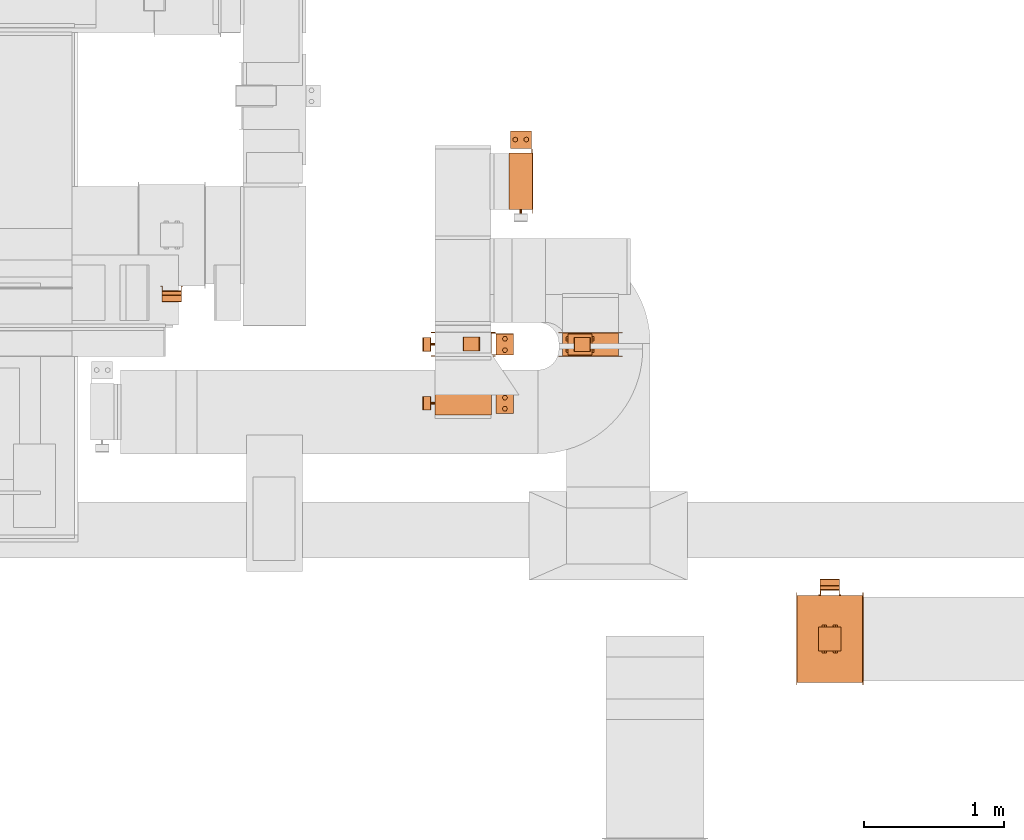
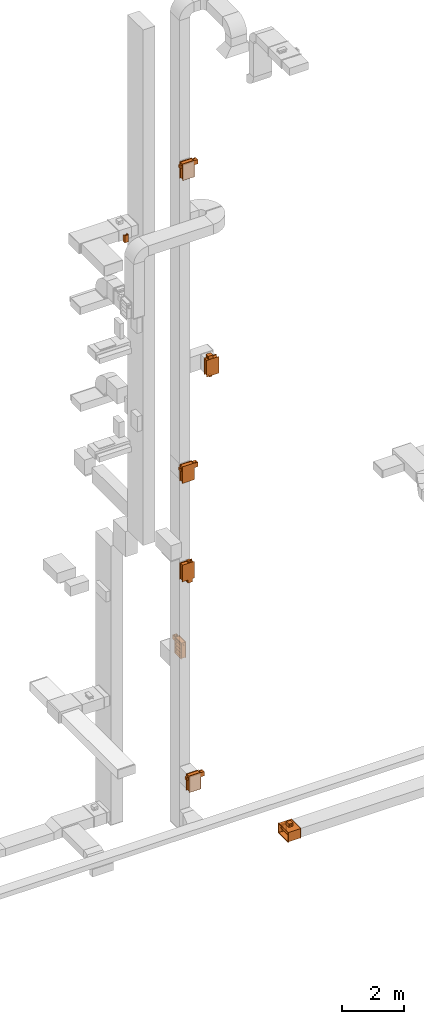
# One storey, part 22 of 25: 14 proxies.
"""IFC2X3 building model written with IfcOpenShell, lengths in millimetres."""

from ifc_helpers import new_model, entity, si_unit, converted_unit, derived_unit, direction, frame, frame_2d, origin, origin_2d_with_axis, place, context, subcontext, project, spatial, polyline, circle_curve, parameter, trimmed, segment, composite_curve, rectangle, circle, hollow_circle, outline, extrude, source, transform, mapped, material, material_list, type_object, type_shapes, element, save


model = new_model("IFC2X3")

# Units and contexts
model_context = context("Model", 3, precision=0.01, world=origin(), true_north=direction((6.12303176911189e-17, 1.0)))
body_context = subcontext(model_context, "Body", "Model", "MODEL_VIEW")
ifc_project = project(units=[si_unit("LENGTHUNIT", "METRE", prefix="MILLI"), si_unit("AREAUNIT", "SQUARE_METRE"), si_unit("VOLUMEUNIT", "CUBIC_METRE"), converted_unit("PLANEANGLEUNIT", "DEGREE", entity("IfcRatioMeasure", 0.0174532925199433), si_unit("PLANEANGLEUNIT", "RADIAN"), dimensions=[0, 0, 0, 0, 0, 0, 0]), si_unit("MASSUNIT", "GRAM", prefix="KILO"), derived_unit("MASSDENSITYUNIT", [(si_unit("MASSUNIT", "GRAM", prefix="KILO"), 1), (si_unit("LENGTHUNIT", "METRE"), -3)]), derived_unit("MOMENTOFINERTIAUNIT", [(si_unit("LENGTHUNIT", "METRE"), 4)]), si_unit("TIMEUNIT", "SECOND"), si_unit("FREQUENCYUNIT", "HERTZ"), si_unit("THERMODYNAMICTEMPERATUREUNIT", "DEGREE_CELSIUS"), derived_unit("THERMALTRANSMITTANCEUNIT", [(si_unit("MASSUNIT", "GRAM", prefix="KILO"), 1), (si_unit("THERMODYNAMICTEMPERATUREUNIT", "KELVIN"), -1), (si_unit("TIMEUNIT", "SECOND"), -3)]), derived_unit("VOLUMETRICFLOWRATEUNIT", [(si_unit("LENGTHUNIT", "METRE"), 3), (si_unit("TIMEUNIT", "SECOND"), -1)]), derived_unit("MASSFLOWRATEUNIT", [(si_unit("MASSUNIT", "GRAM", prefix="KILO"), 1), (si_unit("TIMEUNIT", "SECOND"), -1)]), derived_unit("ROTATIONALFREQUENCYUNIT", [(si_unit("TIMEUNIT", "SECOND"), -1)]), si_unit("ELECTRICCURRENTUNIT", "AMPERE"), si_unit("ELECTRICVOLTAGEUNIT", "VOLT"), si_unit("POWERUNIT", "WATT"), si_unit("FORCEUNIT", "NEWTON", prefix="KILO"), si_unit("ILLUMINANCEUNIT", "LUX"), si_unit("LUMINOUSFLUXUNIT", "LUMEN"), si_unit("LUMINOUSINTENSITYUNIT", "CANDELA"), derived_unit("USERDEFINED", [(si_unit("MASSUNIT", "GRAM", prefix="KILO"), -1), (si_unit("LENGTHUNIT", "METRE"), -2), (si_unit("TIMEUNIT", "SECOND"), 3), (si_unit("LUMINOUSFLUXUNIT", "LUMEN"), 1)]), derived_unit("LINEARVELOCITYUNIT", [(si_unit("LENGTHUNIT", "METRE"), 1), (si_unit("TIMEUNIT", "SECOND"), -1)]), si_unit("PRESSUREUNIT", "PASCAL"), derived_unit("USERDEFINED", [(si_unit("LENGTHUNIT", "METRE"), -2), (si_unit("MASSUNIT", "GRAM", prefix="KILO"), 1), (si_unit("TIMEUNIT", "SECOND"), -2)]), derived_unit("LINEARFORCEUNIT", [(si_unit("MASSUNIT", "GRAM", prefix="KILO"), 1), (si_unit("LENGTHUNIT", "METRE"), 1), (si_unit("TIMEUNIT", "SECOND"), -2), (si_unit("LENGTHUNIT", "METRE"), -1)]), derived_unit("PLANARFORCEUNIT", [(si_unit("MASSUNIT", "GRAM", prefix="KILO"), 1), (si_unit("LENGTHUNIT", "METRE"), 1), (si_unit("TIMEUNIT", "SECOND"), -2), (si_unit("LENGTHUNIT", "METRE"), -2)])], contexts=[model_context])

# Site, building, storey
site_placement = place(None, origin())
site = spatial("IfcSite", under=ifc_project, at=site_placement, CompositionType="ELEMENT")
building_placement = place(site_placement, origin())
building = spatial("IfcBuilding", under=site, at=building_placement, CompositionType="ELEMENT")
storey_placement = place(building_placement, origin())
storey = spatial("IfcBuildingStorey", under=building, at=storey_placement, Name="01", CompositionType="ELEMENT", Elevation=0.0)

# Proxies
ifc_material_1 = material()
ifc_material_2 = material(Name="_ RAL 9003")
ifc_material_3 = material()
ifc_material_4 = material()
ifc_material_list_1 = material_list([ifc_material_1, ifc_material_2, ifc_material_3, ifc_material_4])
ifc_material_list_2 = material_list([ifc_material_1, ifc_material_1, ifc_material_1, ifc_material_1, ifc_material_1, ifc_material_1, ifc_material_1, ifc_material_1, ifc_material_1, ifc_material_1, ifc_material_1, ifc_material_1, ifc_material_1, ifc_material_1, ifc_material_2, ifc_material_3, ifc_material_4, ifc_material_4, ifc_material_4, ifc_material_4, ifc_material_4, ifc_material_4, ifc_material_4, ifc_material_4, ifc_material_4, ifc_material_4])
building_element_proxy_type_1 = type_object("IfcBuildingElementProxyType", PredefinedType="NOTDEFINED", material=ifc_material_list_2)
shared_shape_1 = source(origin(), body_context, "Body", "SweptSolid", [
    extrude(rectangle(XDim=1.50000000000003, YDim=150.0, at=origin_2d_with_axis()), frame((0.0, 202.25, 157.25), z_axis=(0.0, 0.0, 1.0), x_axis=(0.0, -1.0, 0.0)), (0.0, 0.0, 1.0), 123.000000000001),
    extrude(outline(polyline([(-11.67, -10.5), (-10.17, -10.5), (-10.17, 4.5), (21.85, 4.5), (21.85, 6.01), (-11.67, 6.01), (-11.67, -10.5)])), frame((68.99, 224.83, 157.25), z_axis=(0.0, 0.0, 1.0), x_axis=(0.0, -1.0, 0.0)), (0.0, 0.0, 1.0), 25.0),
    extrude(outline(polyline([(-10.5, -11.67), (6.01, -11.67), (6.01, 21.85), (4.5, 21.85), (4.5, -10.17), (-10.5, -10.17), (-10.5, -11.67)])), frame((-68.99, 224.83, 157.25), z_axis=(0.0, 0.0, 1.0), x_axis=(-1.0, 0.0, 0.0)), (0.0, 0.0, 1.0), 25.0000000000005),
    extrude(outline(polyline([(-11.67, -10.5), (-10.17, -10.5), (-10.17, 4.5), (21.85, 4.5), (21.85, 6.01), (-11.67, 6.01), (-11.67, -10.5)])), frame((68.99, 224.83, 255.25), z_axis=(0.0, 0.0, 1.0), x_axis=(0.0, -1.0, 0.0)), (0.0, 0.0, 1.0), 25.0),
    extrude(outline(polyline([(-9.31, -16.13), (9.31, -16.13), (18.63, 0.0), (9.31, 16.13), (-9.31, 16.13), (-18.63, 0.0), (-9.31, -16.13)])), frame((40.0, 299.0, 307.25), z_axis=(0.0, 0.0, 1.0), x_axis=(0.866025403784569, 0.499999999999775, 0.0)), (0.0, 0.0, 1.0), 10.0),
    extrude(outline(polyline([(-9.26, -16.03), (9.26, -16.03), (18.52, 0.0), (9.26, 16.03), (-9.26, 16.03), (-18.52, 0.0), (-9.26, -16.03)])), frame((-40.0, 299.0, 307.25), z_axis=(0.0, 0.0, 1.0), x_axis=(0.866025403784445, 0.499999999999988, 0.0)), (0.0, 0.0, 1.0), 10.0),
    extrude(hollow_circle(Radius=15.0, WallThickness=6.97527274236894, at=origin_2d_with_axis()), frame((-40.0, 299.0, 305.25), z_axis=(0.0, 0.0, 1.0), x_axis=(-1.0, 0.0, 0.0)), (0.0, 0.0, 1.0), 14.0),
    extrude(hollow_circle(Radius=15.0, WallThickness=7.0, at=origin_2d_with_axis()), frame((40.0, 299.0, 305.25), z_axis=(0.0, 0.0, 1.0), x_axis=(-1.0, 0.0, 0.0)), (0.0, 0.0, 1.0), 14.0),
    extrude(outline(polyline([(-10.5, -11.67), (6.01, -11.67), (6.01, 21.85), (4.5, 21.85), (4.5, -10.17), (-10.5, -10.17), (-10.5, -11.67)])), frame((-68.99, 224.83, 255.25), z_axis=(0.0, 0.0, 1.0), x_axis=(-1.0, 0.0, 0.0)), (0.0, 0.0, 1.0), 25.0),
    extrude(outline(polyline([(-9.31, -16.13), (9.31, -16.13), (18.63, 0.0), (9.31, 16.13), (-9.31, 16.13), (-18.63, 0.0), (-9.31, -16.13)])), frame((40.0, 299.0, 120.25), z_axis=(0.0, 0.0, 1.0), x_axis=(0.866025403784588, 0.499999999999741, 0.0)), (0.0, 0.0, 1.0), 9.99999999999999),
    extrude(outline(polyline([(-9.26, -16.03), (9.26, -16.03), (18.52, 0.0), (9.26, 16.03), (-9.26, 16.03), (-18.52, 0.0), (-9.26, -16.03)])), frame((-40.0, 299.0, 120.25), z_axis=(0.0, 0.0, 1.0), x_axis=(0.866025403784446, 0.499999999999988, 0.0)), (0.0, 0.0, 1.0), 9.99999999999999),
    extrude(hollow_circle(Radius=15.0, WallThickness=6.97527274236894, at=origin_2d_with_axis()), frame((-40.0, 299.0, 118.25), z_axis=(0.0, 0.0, 1.0), x_axis=(-1.0, 0.0, 0.0)), (0.0, 0.0, 1.0), 14.0000000000001),
    extrude(hollow_circle(Radius=15.0, WallThickness=7.0, at=origin_2d_with_axis()), frame((40.0, 299.0, 118.25), z_axis=(0.0, 0.0, 1.0), x_axis=(-1.0, 0.0, 0.0)), (0.0, 0.0, 1.0), 14.0000000000001),
    extrude(rectangle(XDim=125.0, YDim=150.0, at=origin_2d_with_axis()), frame((0.0, 299.0, 132.25), z_axis=(0.0, 0.0, 1.0), x_axis=(0.0, -1.0, 0.0)), (0.0, 0.0, 1.0), 173.0),
    extrude(outline(polyline([(-91.92, -374.77), (-49.5, -374.77), (374.77, 49.5), (374.77, 91.92), (91.92, 374.77), (49.5, 374.77), (-374.77, -49.5), (-374.77, -91.92), (-91.92, -374.77)]), holes=[polyline([(-70.71, -353.55), (-353.55, -70.71), (70.71, 353.55), (353.55, 70.71), (-70.71, -353.55)])]), frame((85.0, 0.0, 0.0), z_axis=(1.0, 0.0, 0.0), x_axis=(0.0, -0.707106781186547, -0.707106781186548)), (0.0, 0.0, 1.0), 1.50000000000001),
    extrude(rectangle(XDim=1.5, YDim=400.0, at=origin_2d_with_axis()), frame((85.75, 0.0, -300.0)), (0.0, 0.0, 1.0), 600.0),
    extrude(outline(polyline([(-10.76, -14.99), (14.24, -14.99), (69.83, -6.99), (69.83, 6.98), (14.24, 15.01), (-10.76, 15.01), (-73.31, 6.98), (-73.31, -6.99), (-10.76, -14.99)])), frame((-1.2, -201.5, 70.92), z_axis=(0.0, 1.0, 0.0), x_axis=(0.707106781186548, 0.0, 0.707106781186548)), (0.0, 0.0, 1.0), 400.0),
    extrude(outline(polyline([(-10.76, -14.99), (14.24, -14.99), (69.83, -6.99), (69.83, 6.98), (14.24, 15.01), (-10.76, 15.01), (-73.31, 6.98), (-73.31, -6.99), (-10.76, -14.99)])), frame((-1.2, -201.5, -73.91), z_axis=(0.0, 1.0, 0.0), x_axis=(0.707106781186548, 0.0, 0.707106781186548)), (0.0, 0.0, 1.0), 400.0),
    extrude(outline(polyline([(-10.76, -14.99), (14.24, -14.99), (69.83, -6.99), (69.83, 6.98), (14.24, 15.01), (-10.76, 15.01), (-73.31, 6.98), (-73.31, -6.99), (-10.76, -14.99)])), frame((-1.2, -201.5, 215.75), z_axis=(0.0, 1.0, 0.0), x_axis=(0.707106781186548, 0.0, 0.707106781186548)), (0.0, 0.0, 1.0), 400.0),
    extrude(outline(polyline([(-10.76, -14.99), (14.24, -14.99), (69.83, -6.99), (69.83, 6.98), (14.24, 15.01), (-10.76, 15.01), (-73.31, 6.98), (-73.31, -6.99), (-10.76, -14.99)])), frame((-1.2, -201.5, -218.75), z_axis=(0.0, 1.0, 0.0), x_axis=(0.707106781186548, 0.0, 0.707106781186548)), (0.0, 0.0, 1.0), 400.0),
    extrude(outline(polyline([(-201.5, -301.5), (201.5, -301.5), (201.5, 301.5), (-201.5, 301.5), (-201.5, -301.5)]), holes=[polyline([(200.0, -300.0), (-200.0, -300.0), (-200.0, 300.0), (200.0, 300.0), (200.0, -300.0)])]), frame((-83.5, 0.0, 0.0), z_axis=(1.0, 0.0, 0.0), x_axis=(0.0, -1.0, 0.0)), (0.0, 0.0, 1.0), 167.0),
    extrude(rectangle(XDim=1.5, YDim=400.000000000054, at=origin_2d_with_axis()), frame((-0.75, 0.0, 291.0), z_axis=(0.0, 0.0, 1.0), x_axis=(-1.0, 0.0, 0.0)), (0.0, 0.0, 1.0), 8.99999999964964),
    extrude(rectangle(XDim=1.5, YDim=399.999999999998, at=origin_2d_with_axis()), frame((-0.75, 0.0, -300.0), z_axis=(0.0, 0.0, 1.0), x_axis=(-1.0, 0.0, 0.0)), (0.0, 0.0, 1.0), 9.00000000035571),
    extrude(outline(polyline([(-330.0, -229.98), (-301.5, -229.98), (301.5, -229.98), (330.0, -229.98), (330.0, 229.98), (301.5, 229.98), (-301.5, 229.98), (-330.0, 229.98), (-330.0, -229.98)]), holes=[polyline([(-300.0, 200.02), (300.0, 200.02), (300.0, -199.98), (-300.0, -199.98), (-300.0, 200.02)])]), frame((83.5, -0.02, 0.0), z_axis=(1.0, 0.0, 0.0), x_axis=(0.0, 0.0, -1.0)), (0.0, 0.0, 1.0), 1.49999999999925),
    extrude(outline(polyline([(-330.0, -229.98), (-301.5, -229.98), (301.5, -229.98), (330.0, -229.98), (330.0, 229.98), (301.5, 229.98), (-301.5, 229.98), (-330.0, 229.98), (-330.0, -229.98)]), holes=[polyline([(-300.0, 200.02), (300.0, 200.02), (300.0, -199.98), (-300.0, -199.98), (-300.0, 200.02)])]), frame((-85.0, -0.02, 0.0), z_axis=(1.0, 0.0, 0.0), x_axis=(0.0, 0.0, -1.0)), (0.0, 0.0, 1.0), 1.50000000000074),
    extrude(circle(Radius=8.0, at=origin_2d_with_axis()), frame((0.0, -230.0, 218.75), z_axis=(0.0, 1.0, 0.0), x_axis=(0.0, 0.0, 1.0)), (0.0, 0.0, 1.0), 28.5),
])
type_shapes(building_element_proxy_type_1, [shared_shape_1])
for number, where, z_axis, x_axis in (
    (1, (31869.89, 10507.42, 24600.0), (0.0, 0.0, 1.0), (0.0, -1.0, 0.0)),
    (2, (31869.89, 10510.0, 12600.0), (0.0, 0.0, 1.0), (0.0, -1.0, 0.0)),
):
    element("IfcBuildingElementProxy", number, at=place(storey_placement, frame(where, z_axis=z_axis, x_axis=x_axis)), inside=storey, type_object=building_element_proxy_type_1, material=ifc_material_list_1, context=body_context, shape_type="MappedRepresentation", body=[
        mapped(shared_shape_1, transform((0.0, 0.0, 0.0), scale=1.0)),
    ])
proxy_1_placement = place(storey_placement, frame((32282.98, 11675.23, 4800.0)))
element("IfcBuildingElementProxy", 3, at=proxy_1_placement, inside=storey, type_object=building_element_proxy_type_1, material=ifc_material_list_1, context=body_context, shape_type="MappedRepresentation", body=[
    mapped(shared_shape_1, transform((0.0, 0.0, 0.0), scale=1.0)),
])
proxy_2_placement = place(storey_placement, frame((31869.89, 10087.24, 600.0), z_axis=(0.0, 0.0, 1.0), x_axis=(0.0, -1.0, 0.0)))
element("IfcBuildingElementProxy", 4, at=proxy_2_placement, inside=storey, type_object=building_element_proxy_type_1, material=ifc_material_list_1, context=body_context, shape_type="MappedRepresentation", body=[
    mapped(shared_shape_1, transform((0.0, 0.0, 0.0), scale=1.0)),
])
ifc_material_list_3 = material_list([ifc_material_1, ifc_material_1, ifc_material_1, ifc_material_1, ifc_material_1, ifc_material_1, ifc_material_1, ifc_material_1, ifc_material_1, ifc_material_1, ifc_material_1, ifc_material_1, ifc_material_1, ifc_material_1, ifc_material_2, ifc_material_3, ifc_material_4, ifc_material_4, ifc_material_4, ifc_material_4, ifc_material_4, ifc_material_4, ifc_material_4, ifc_material_4])
building_element_proxy_type_2 = type_object("IfcBuildingElementProxyType", PredefinedType="NOTDEFINED", material=ifc_material_list_3)
shared_shape_2 = source(origin(), body_context, "Body", "SweptSolid", [
    extrude(rectangle(XDim=1.50000000000003, YDim=150.0, at=origin_2d_with_axis()), frame((0.0, 302.25, 12.75), z_axis=(0.0, 0.0, 1.0), x_axis=(0.0, -1.0, 0.0)), (0.0, 0.0, 1.0), 123.000000000001),
    extrude(outline(polyline([(-11.67, -10.5), (-10.17, -10.5), (-10.17, 4.5), (21.85, 4.5), (21.85, 6.01), (-11.67, 6.01), (-11.67, -10.5)])), frame((68.99, 324.83, 12.75), z_axis=(0.0, 0.0, 1.0), x_axis=(0.0, -1.0, 0.0)), (0.0, 0.0, 1.0), 25.0),
    extrude(outline(polyline([(-10.5, -11.67), (6.01, -11.67), (6.01, 21.85), (4.5, 21.85), (4.5, -10.17), (-10.5, -10.17), (-10.5, -11.67)])), frame((-68.99, 324.83, 12.75), z_axis=(0.0, 0.0, 1.0), x_axis=(-1.0, 0.0, 0.0)), (0.0, 0.0, 1.0), 25.0000000000005),
    extrude(outline(polyline([(-11.67, -10.5), (-10.17, -10.5), (-10.17, 4.5), (21.85, 4.5), (21.85, 6.01), (-11.67, 6.01), (-11.67, -10.5)])), frame((68.99, 324.83, 110.75), z_axis=(0.0, 0.0, 1.0), x_axis=(0.0, -1.0, 0.0)), (0.0, 0.0, 1.0), 25.0),
    extrude(outline(polyline([(-9.31, -16.13), (9.31, -16.13), (18.63, 0.0), (9.31, 16.13), (-9.31, 16.13), (-18.63, 0.0), (-9.31, -16.13)])), frame((40.0, 399.0, 162.75), z_axis=(0.0, 0.0, 1.0), x_axis=(0.866025403784569, 0.499999999999774, 0.0)), (0.0, 0.0, 1.0), 9.99999999999999),
    extrude(outline(polyline([(-9.26, -16.03), (9.26, -16.03), (18.52, 0.0), (9.26, 16.03), (-9.26, 16.03), (-18.52, 0.0), (-9.26, -16.03)])), frame((-40.0, 399.0, 162.75), z_axis=(0.0, 0.0, 1.0), x_axis=(0.866025403784445, 0.499999999999988, 0.0)), (0.0, 0.0, 1.0), 9.99999999999999),
    extrude(hollow_circle(Radius=15.0, WallThickness=6.97527274236894, at=origin_2d_with_axis()), frame((-40.0, 399.0, 160.75), z_axis=(0.0, 0.0, 1.0), x_axis=(-1.0, 0.0, 0.0)), (0.0, 0.0, 1.0), 14.0),
    extrude(hollow_circle(Radius=15.0, WallThickness=7.0, at=origin_2d_with_axis()), frame((40.0, 399.0, 160.75), z_axis=(0.0, 0.0, 1.0), x_axis=(-1.0, 0.0, 0.0)), (0.0, 0.0, 1.0), 14.0),
    extrude(outline(polyline([(-10.5, -11.67), (6.01, -11.67), (6.01, 21.85), (4.5, 21.85), (4.5, -10.17), (-10.5, -10.17), (-10.5, -11.67)])), frame((-68.99, 324.83, 110.75), z_axis=(0.0, 0.0, 1.0), x_axis=(-1.0, 0.0, 0.0)), (0.0, 0.0, 1.0), 25.0),
    extrude(outline(polyline([(-9.31, -16.13), (9.31, -16.13), (18.63, 0.0), (9.31, 16.13), (-9.31, 16.13), (-18.63, 0.0), (-9.31, -16.13)])), frame((40.0, 399.0, -24.25), z_axis=(0.0, 0.0, 1.0), x_axis=(0.866025403784589, 0.499999999999739, 0.0)), (0.0, 0.0, 1.0), 10.0),
    extrude(outline(polyline([(-9.26, -16.03), (9.26, -16.03), (18.52, 0.0), (9.26, 16.03), (-9.26, 16.03), (-18.52, 0.0), (-9.26, -16.03)])), frame((-40.0, 399.0, -24.25), z_axis=(0.0, 0.0, 1.0), x_axis=(0.866025403784447, 0.499999999999985, 0.0)), (0.0, 0.0, 1.0), 9.99999999999999),
    extrude(hollow_circle(Radius=15.0, WallThickness=6.97527274236894, at=origin_2d_with_axis()), frame((-40.0, 399.0, -26.25), z_axis=(0.0, 0.0, 1.0), x_axis=(-1.0, 0.0, 0.0)), (0.0, 0.0, 1.0), 14.0000000000001),
    extrude(hollow_circle(Radius=15.0, WallThickness=7.0, at=origin_2d_with_axis()), frame((40.0, 399.0, -26.25), z_axis=(0.0, 0.0, 1.0), x_axis=(-1.0, 0.0, 0.0)), (0.0, 0.0, 1.0), 14.0000000000001),
    extrude(rectangle(XDim=125.0, YDim=150.0, at=origin_2d_with_axis()), frame((0.0, 399.0, -12.25), z_axis=(0.0, 0.0, 1.0), x_axis=(0.0, -1.0, 0.0)), (0.0, 0.0, 1.0), 173.0),
    extrude(outline(polyline([(49.5, -374.77), (91.92, -374.77), (374.77, -91.92), (374.77, -49.5), (-49.5, 374.77), (-91.92, 374.77), (-374.77, 91.92), (-374.77, 49.5), (49.5, -374.77)]), holes=[polyline([(70.71, -353.55), (-353.55, 70.71), (-70.71, 353.55), (353.55, -70.71), (70.71, -353.55)])]), frame((85.0, 0.0, 0.0), z_axis=(1.0, 0.0, 0.0), x_axis=(0.0, -0.707106781186548, -0.707106781186547)), (0.0, 0.0, 1.0), 1.5),
    extrude(rectangle(XDim=1.5, YDim=600.0, at=origin_2d_with_axis()), frame((85.75, 0.0, -200.0)), (0.0, 0.0, 1.0), 400.0),
    extrude(outline(polyline([(-10.76, -14.99), (14.24, -14.99), (69.83, -6.99), (69.83, 6.98), (14.24, 15.01), (-10.76, 15.01), (-73.31, 6.98), (-73.31, -6.99), (-10.76, -14.99)])), frame((-1.2, -301.5, 71.25), z_axis=(0.0, 1.0, 0.0), x_axis=(0.707106781186548, 0.0, 0.707106781186548)), (0.0, 0.0, 1.0), 600.0),
    extrude(outline(polyline([(-10.76, -14.99), (14.24, -14.99), (69.83, -6.99), (69.83, 6.98), (14.24, 15.01), (-10.76, 15.01), (-73.31, 6.98), (-73.31, -6.99), (-10.76, -14.99)])), frame((-1.2, -301.5, -74.25), z_axis=(0.0, 1.0, 0.0), x_axis=(0.707106781186547, 0.0, 0.707106781186548)), (0.0, 0.0, 1.0), 600.0),
    extrude(outline(polyline([(-301.5, -201.5), (301.5, -201.5), (301.5, 201.5), (-301.5, 201.5), (-301.5, -201.5)]), holes=[polyline([(300.0, -200.0), (-300.0, -200.0), (-300.0, 200.0), (300.0, 200.0), (300.0, -200.0)])]), frame((-83.5, 0.0, 0.0), z_axis=(1.0, 0.0, 0.0), x_axis=(0.0, -1.0, 0.0)), (0.0, 0.0, 1.0), 167.0),
    extrude(rectangle(XDim=1.5, YDim=600.000000000054, at=origin_2d_with_axis()), frame((-0.75, 0.0, 146.5), z_axis=(0.0, 0.0, 1.0), x_axis=(-1.0, 0.0, 0.0)), (0.0, 0.0, 1.0), 53.4999999996496),
    extrude(rectangle(XDim=1.5, YDim=599.999999999997, at=origin_2d_with_axis()), frame((-0.75, 0.0, -200.0), z_axis=(0.0, 0.0, 1.0), x_axis=(-1.0, 0.0, 0.0)), (0.0, 0.0, 1.0), 53.5000000003557),
    extrude(outline(polyline([(-230.0, -329.98), (-201.5, -329.98), (201.5, -329.98), (230.0, -329.98), (230.0, 329.98), (201.5, 329.98), (-201.5, 329.98), (-230.0, 329.98), (-230.0, -329.98)]), holes=[polyline([(-200.0, 300.02), (200.0, 300.02), (200.0, -299.98), (-200.0, -299.98), (-200.0, 300.02)])]), frame((83.5, -0.02, 0.0), z_axis=(1.0, 0.0, 0.0), x_axis=(0.0, 0.0, -1.0)), (0.0, 0.0, 1.0), 1.49999999999925),
    extrude(outline(polyline([(-230.0, -329.98), (-201.5, -329.98), (201.5, -329.98), (230.0, -329.98), (230.0, 329.98), (201.5, 329.98), (-201.5, 329.98), (-230.0, 329.98), (-230.0, -329.98)]), holes=[polyline([(-200.0, 300.02), (200.0, 300.02), (200.0, -299.98), (-200.0, -299.98), (-200.0, 300.02)])]), frame((-85.0, -0.02, 0.0), z_axis=(1.0, 0.0, 0.0), x_axis=(0.0, 0.0, -1.0)), (0.0, 0.0, 1.0), 1.50000000000074),
    extrude(circle(Radius=8.0, at=origin_2d_with_axis()), frame((0.0, -330.0, 74.25), z_axis=(0.0, 1.0, 0.0), x_axis=(0.0, 0.0, 1.0)), (0.0, 0.0, 1.0), 28.5),
])
type_shapes(building_element_proxy_type_2, [shared_shape_2])
proxy_3_placement = place(storey_placement, frame((32781.63, 10507.06, 16500.0), z_axis=(-1.0, 0.0, 0.0), x_axis=(0.0, -1.0, 0.0)))
element("IfcBuildingElementProxy", 5, at=proxy_3_placement, inside=storey, type_object=building_element_proxy_type_2, material=ifc_material_list_3, context=body_context, shape_type="MappedRepresentation", body=[
    mapped(shared_shape_2, transform((0.0, 0.0, 0.0), scale=1.0)),
])
proxy_4_placement = place(storey_placement, frame((31869.89, 10510.38, 8700.0), z_axis=(1.0, 0.0, 0.0), x_axis=(0.0, -1.0, 0.0)))
element("IfcBuildingElementProxy", 6, at=proxy_4_placement, inside=storey, type_object=building_element_proxy_type_2, material=ifc_material_list_1, context=body_context, shape_type="MappedRepresentation", body=[
    mapped(shared_shape_2, transform((0.0, 0.0, 0.0), scale=1.0)),
])
ifc_material_list_4 = material_list([ifc_material_1, ifc_material_1, ifc_material_1, ifc_material_1, ifc_material_1, ifc_material_1, ifc_material_1, ifc_material_1, ifc_material_1, ifc_material_1, ifc_material_1, ifc_material_1, ifc_material_1, ifc_material_1, ifc_material_4, ifc_material_4, ifc_material_4, ifc_material_4, ifc_material_4])
building_element_proxy_type_3 = type_object("IfcBuildingElementProxyType", PredefinedType="NOTDEFINED", material=ifc_material_list_4)
shared_shape_3 = source(origin(), body_context, "Body", "SweptSolid", [
    extrude(rectangle(XDim=1.5, YDim=170.0, at=origin_2d_with_axis()), frame((0.0, -187.75, -62.0), z_axis=(0.0, 0.0, 1.0), x_axis=(0.0, 1.0, 0.0)), (0.0, 0.0, 1.0), 123.000000000001),
    extrude(outline(polyline([(-5.01, -14.16), (-3.51, -14.16), (-3.51, 6.33), (8.51, 6.33), (8.51, 7.84), (-5.01, 7.84), (-5.01, -14.16)])), frame((-72.16, -196.99, -62.0), z_axis=(0.0, 0.0, 1.0), x_axis=(0.0, 1.0, 0.0)), (0.0, 0.0, 1.0), 25.0),
    extrude(outline(polyline([(-13.84, -5.01), (7.67, -5.01), (7.67, 8.51), (6.16, 8.51), (6.16, -3.51), (-13.84, -3.51), (-13.84, -5.01)])), frame((72.33, -196.99, -62.0)), (0.0, 0.0, 1.0), 25.0000000000005),
    extrude(outline(polyline([(-5.01, -14.16), (-3.51, -14.16), (-3.51, 6.33), (8.51, 6.33), (8.51, 7.84), (-5.01, 7.84), (-5.01, -14.16)])), frame((-72.16, -196.99, 36.0), z_axis=(0.0, 0.0, 1.0), x_axis=(0.0, 1.0, 0.0)), (0.0, 0.0, 1.0), 25.0),
    extrude(outline(polyline([(-9.39, -16.09), (8.81, -16.09), (18.35, -0.08), (9.67, 15.92), (-8.96, 16.17), (-18.49, 0.17), (-9.39, -16.09)])), frame((-39.84, -264.5, 88.0), z_axis=(0.0, 0.0, 1.0), x_axis=(-0.859210135894937, -0.511622851693906, 0.0)), (0.0, 0.0, 1.0), 9.99999999999999),
    extrude(outline(polyline([(-9.26, -16.03), (9.26, -16.03), (18.52, 0.0), (9.26, 16.03), (-9.26, 16.03), (-18.52, 0.0), (-9.26, -16.03)])), frame((40.0, -264.5, 88.0), z_axis=(0.0, 0.0, 1.0), x_axis=(-0.86602540378445, -0.499999999999979, 0.0)), (0.0, 0.0, 1.0), 10.0),
    extrude(hollow_circle(Radius=15.0, WallThickness=6.97527274236894, at=origin_2d_with_axis()), frame((40.0, -264.5, 86.0)), (0.0, 0.0, 1.0), 14.0),
    extrude(hollow_circle(Radius=15.0, WallThickness=7.0, at=origin_2d_with_axis()), frame((-40.0, -264.5, 86.0)), (0.0, 0.0, 1.0), 14.0),
    extrude(outline(polyline([(-13.84, -5.01), (7.67, -5.01), (7.67, 8.51), (6.16, 8.51), (6.16, -3.51), (-13.84, -3.51), (-13.84, -5.01)])), frame((72.33, -196.99, 36.0)), (0.0, 0.0, 1.0), 25.0),
    extrude(outline(polyline([(-9.39, -16.09), (8.81, -16.09), (18.35, -0.08), (9.67, 15.92), (-8.96, 16.17), (-18.49, 0.17), (-9.39, -16.09)])), frame((-39.84, -264.5, -98.0), z_axis=(0.0, 0.0, 1.0), x_axis=(-0.859210135895012, -0.511622851693779, 0.0)), (0.0, 0.0, 1.0), 9.99999999999999),
    extrude(outline(polyline([(-9.26, -16.03), (9.26, -16.03), (18.52, 0.0), (9.26, 16.03), (-9.26, 16.03), (-18.52, 0.0), (-9.26, -16.03)])), frame((40.0, -264.5, -98.0), z_axis=(0.0, 0.0, 1.0), x_axis=(-0.866025403784445, -0.49999999999999, 0.0)), (0.0, 0.0, 1.0), 9.99999999999999),
    extrude(hollow_circle(Radius=15.0, WallThickness=6.97527274236894, at=origin_2d_with_axis()), frame((40.0, -264.5, -100.0)), (0.0, 0.0, 1.0), 14.0000000000002),
    extrude(hollow_circle(Radius=15.0, WallThickness=7.0, at=origin_2d_with_axis()), frame((-40.0, -264.5, -100.0)), (0.0, 0.0, 1.0), 14.0000000000002),
    extrude(rectangle(XDim=127.0, YDim=159.999999999992, at=origin_2d_with_axis()), frame((0.0, -265.5, -86.0), z_axis=(0.0, 0.0, 1.0), x_axis=(0.0, 1.0, 0.0)), (0.0, 0.0, 1.0), 171.999999999999),
    extrude(outline(polyline([(-187.0, -312.0), (187.0, -312.0), (187.0, 312.0), (-187.0, 312.0), (-187.0, -312.0)]), holes=[polyline([(175.0, 300.0), (175.0, -300.0), (-175.0, -300.0), (-175.0, 300.0), (175.0, 300.0)])]), frame((-240.0, 0.0, 0.0), z_axis=(1.0, 0.0, 0.0), x_axis=(0.0, -1.0, 0.0)), (0.0, 0.0, 1.0), 480.0),
    extrude(rectangle(XDim=346.0, YDim=24.0000000000003, at=origin_2d_with_axis()), frame((0.0, 0.0, -288.0), z_axis=(0.0, 0.0, 1.0), x_axis=(-1.0, 0.0, 0.0)), (0.0, 0.0, 1.0), 576.000000000017),
    extrude(outline(polyline([(-205.0, -330.0), (205.0, -330.0), (205.0, 330.0), (-205.0, 330.0), (-205.0, -330.0)]), holes=[polyline([(-175.0, -300.0), (-175.0, 300.0), (175.0, 300.0), (175.0, -300.0), (-175.0, -300.0)])]), frame((235.0, 0.0, 0.0), z_axis=(1.0, 0.0, 0.0), x_axis=(0.0, -1.0, 0.0)), (0.0, 0.0, 1.0), 5.00000000000319),
    extrude(outline(polyline([(-205.0, -330.0), (205.0, -330.0), (205.0, 330.0), (-205.0, 330.0), (-205.0, -330.0)]), holes=[polyline([(-175.0, -300.0), (-175.0, 300.0), (175.0, 300.0), (175.0, -300.0), (-175.0, -300.0)])]), frame((-240.0, 0.0, 0.0), z_axis=(1.0, 0.0, 0.0), x_axis=(0.0, -1.0, 0.0)), (0.0, 0.0, 1.0), 4.99999999999991),
    extrude(outline(polyline([(-300.0, -175.0), (300.0, -175.0), (300.0, 175.0), (-300.0, 175.0), (-300.0, -175.0)]), holes=[polyline([(288.0, -163.0), (-288.0, -163.0), (-288.0, 163.0), (288.0, 163.0), (288.0, -163.0)])]), frame((-6.0, 0.0, 0.0), z_axis=(1.0, 0.0, 0.0), x_axis=(0.0, 0.0, -1.0)), (0.0, 0.0, 1.0), 12.0),
])
type_shapes(building_element_proxy_type_3, [shared_shape_3])
proxy_5_placement = place(storey_placement, frame((34495.4, 8400.0, -1250.0), z_axis=(0.0, 1.0, 0.0), x_axis=(1.0, 0.0, 0.0)))
element("IfcBuildingElementProxy", 7, at=proxy_5_placement, inside=storey, type_object=building_element_proxy_type_3, material=ifc_material_list_4, context=body_context, shape_type="MappedRepresentation", body=[
    mapped(shared_shape_3, transform((0.0, 0.0, 0.0), scale=1.0)),
])
ifc_material_5 = material()
ifc_material_list_5 = material_list([ifc_material_5, ifc_material_4])
ifc_material_list_6 = material_list([ifc_material_5, ifc_material_5, ifc_material_4])
building_element_proxy_type_4 = type_object("IfcBuildingElementProxyType", Name="_-1_24:_-1_24", PredefinedType="NOTDEFINED", material=ifc_material_list_6)
shared_shape_4 = source(origin(), body_context, "Body", "SweptSolid", [
    extrude(outline(composite_curve([segment(polyline([(-18.16, -147.54), (18.05, -147.54)]), True, "CONTINUOUS"), segment(trimmed(circle_curve(frame_2d((18.05, -139.09), x_axis=(0.0, -1.0)), 8.44431603721898), [parameter(1.01777749806833e-13)], [parameter(90.0)], True, "PARAMETER"), True, "CONTINUOUS"), segment(polyline([(26.49, -139.09), (26.49, 139.31)]), True, "CONTINUOUS"), segment(trimmed(circle_curve(frame_2d((18.33, 139.31), x_axis=(0.0, -1.0)), 8.15582249386043), [parameter(90.0)], [parameter(180.0)], True, "PARAMETER"), True, "CONTINUOUS"), segment(polyline([(18.33, 147.46), (-18.18, 147.46)]), True, "CONTINUOUS"), segment(trimmed(circle_curve(frame_2d((-18.18, 139.13), x_axis=(0.0, -1.0)), 8.33189596389998), [parameter(180.0)], [parameter(270.0)], True, "PARAMETER"), True, "CONTINUOUS"), segment(polyline([(-26.51, 139.13), (-26.51, -139.19)]), True, "CONTINUOUS"), segment(trimmed(circle_curve(frame_2d((-18.16, -139.19), x_axis=(0.0, -1.0)), 8.35260143157827), [parameter(270.0)], [parameter(4.57999874130747e-13)], True, "PARAMETER"), True, "CONTINUOUS")], self_intersect=False)), frame((-70.0, 12.54, 91.49), z_axis=(1.0, 0.0, 0.0), x_axis=(0.0, 0.0, -1.0)), (0.0, 0.0, 1.0), 139.999999999992),
    extrude(outline(polyline([(-9.17, -80.0), (-4.17, -80.0), (-4.17, -70.0), (15.83, -70.0), (15.83, 70.0), (-4.17, 70.0), (-4.17, 80.0), (-9.17, 80.0), (-9.17, 65.0), (10.83, 65.0), (10.83, -65.0), (-9.17, -65.0), (-9.17, -80.0)])), frame((-70.0, 0.0, 49.17), z_axis=(1.0, 0.0, 0.0), x_axis=(0.0, 0.0, 1.0)), (0.0, 0.0, 1.0), 139.999999999992),
    extrude(outline(polyline([(-14.17, -80.0), (-9.17, -80.0), (-9.17, -70.0), (25.83, -70.0), (25.83, 70.0), (-9.17, 70.0), (-9.17, 80.0), (-14.17, 80.0), (-14.17, 65.0), (20.83, 65.0), (20.83, -65.0), (-14.17, -65.0), (-14.17, -80.0)])), frame((0.0, -135.0, 14.17), z_axis=(0.0, 1.0, 0.0), x_axis=(0.0, 0.0, 1.0)), (0.0, 0.0, 1.0), 270.0),
])
type_shapes(building_element_proxy_type_4, [shared_shape_4])
for number, where, z_axis, x_axis, name in (
    (8, (29783.91, 10927.62, 22380.0), (0.0, -1.0, 0.0), (1.0, 0.0, 0.0), "_-1_24:_-1_24"),
    (9, (34495.4, 8712.0, -1370.0), (0.0, 1.0, 0.0), (-1.0, 0.0, 0.0), "_-1_24:_-1_24"),
):
    element("IfcBuildingElementProxy", number, at=place(storey_placement, frame(where, z_axis=z_axis, x_axis=x_axis)), inside=storey, type_object=building_element_proxy_type_4, material=ifc_material_list_5, Name=name, ObjectType="_-1_24:_-1_24", context=body_context, shape_type="MappedRepresentation", body=[
        mapped(shared_shape_4, transform((0.0, 0.0, 0.0), scale=1.0)),
    ])
building_element_proxy_type_5 = type_object("IfcBuildingElementProxyType", Name="_-_24:_-_24", PredefinedType="NOTDEFINED", material=ifc_material_5)
shared_shape_5 = source(origin(), body_context, "Body", "SweptSolid", [
    extrude(outline(composite_curve([segment(trimmed(circle_curve(frame_2d((51.69, 21.66), x_axis=(1.0, 0.0)), 8.35260143157827), [parameter(360.0)], [parameter(89.9999999999998)], True, "PARAMETER"), True, "CONTINUOUS"), segment(polyline([(51.69, 30.01), (-51.63, 30.01)]), True, "CONTINUOUS"), segment(trimmed(circle_curve(frame_2d((-51.63, 21.68), x_axis=(1.0, 0.0)), 8.33189596389998), [parameter(90.0000000000001)], [parameter(180.0)], True, "PARAMETER"), True, "CONTINUOUS"), segment(polyline([(-59.96, 21.68), (-59.96, -21.83)]), True, "CONTINUOUS"), segment(trimmed(circle_curve(frame_2d((-51.81, -21.83), x_axis=(1.0, 0.0)), 8.15582249386043), [parameter(180.0)], [parameter(270.0)], True, "PARAMETER"), True, "CONTINUOUS"), segment(polyline([(-51.81, -29.99), (51.59, -29.99)]), True, "CONTINUOUS"), segment(trimmed(circle_curve(frame_2d((51.59, -21.55), x_axis=(1.0, 0.0)), 8.44431603721898), [parameter(270.0)], [parameter(0.0)], True, "PARAMETER"), True, "CONTINUOUS"), segment(polyline([(60.04, -21.55), (60.04, 21.66)]), True, "CONTINUOUS")], self_intersect=False)), frame((-49.0, 14.96, 29.99), z_axis=(1.0, 0.0, 0.0), x_axis=(0.0, 1.0, 0.0)), (0.0, 0.0, 1.0), 98.0),
])
type_shapes(building_element_proxy_type_5, [shared_shape_5])
for number, where, z_axis, x_axis, name in (
    (10, (31639.89, 10087.24, 818.75), (-1.0, 0.0, 0.0), (0.0, 1.0, 0.0), "_-_24:_-_24"),
    (11, (31944.14, 10510.38, 9030.0), (0.0, 0.0, 1.0), (0.0, 1.0, 0.0), "_-_24:_-_24"),
    (12, (31639.89, 10507.42, 24818.75), (-1.0, 0.0, 0.0), (0.0, 1.0, 0.0), "_-_24:_-_24"),
    (13, (31639.89, 10510.0, 12818.75), (-1.0, 0.0, 0.0), (0.0, 1.0, 0.0), "_-_24:_-_24"),
    (14, (32707.38, 10507.06, 16170.0), (0.0, 0.0, -1.0), (0.0, 1.0, 0.0), "_-_24:_-_24"),
):
    element("IfcBuildingElementProxy", number, at=place(storey_placement, frame(where, z_axis=z_axis, x_axis=x_axis)), inside=storey, type_object=building_element_proxy_type_5, material=ifc_material_5, Name=name, ObjectType="_-_24:_-_24", context=body_context, shape_type="MappedRepresentation", body=[
        mapped(shared_shape_5, transform((0.0, 0.0, 0.0), scale=1.0)),
    ])

save(model, "model.ifc")
